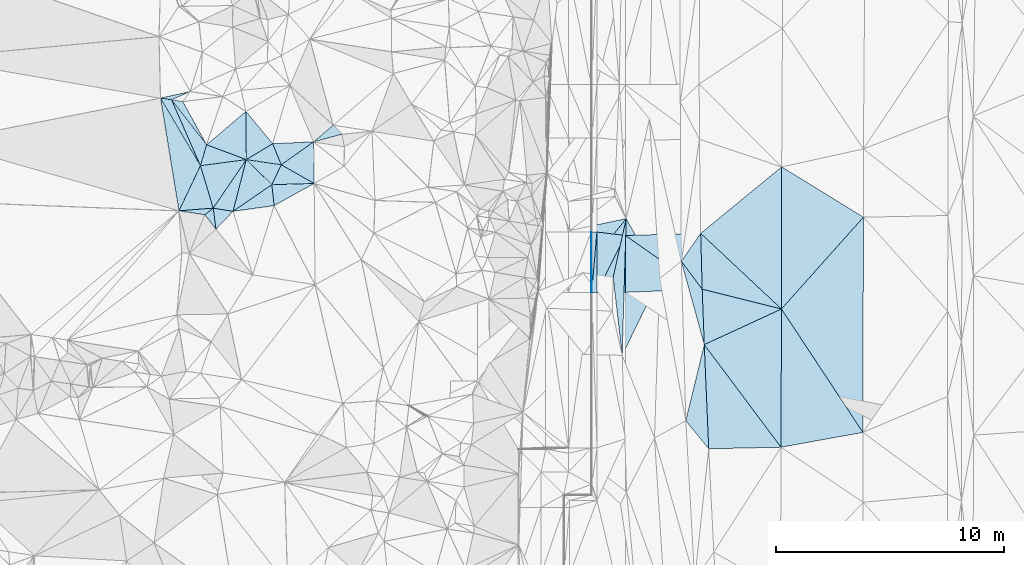
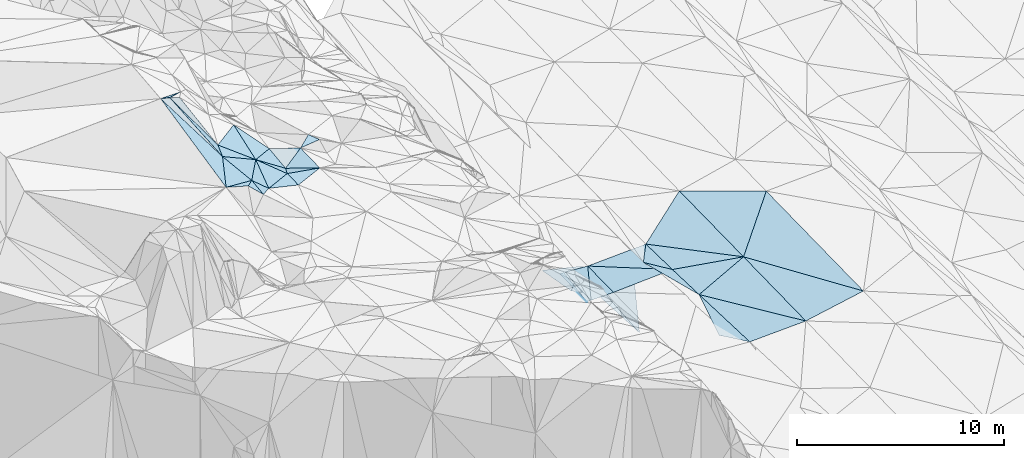
# One storey, part 131 of 275: 45 plates.
"""IFC2X3 building model written with IfcOpenShell, lengths in millimetres."""

from ifc_helpers import new_model, si_unit, frame, origin_with_axes, place, context, subcontext, project, spatial, polyline, outline, extrude, material, type_object, element, save


model = new_model("IFC2X3")

# Units and contexts
model_context = context("Model", 3, precision=1e-05, world=origin_with_axes())
body_context = subcontext(model_context, "Body", "Model", "MODEL_VIEW")
ifc_project = project(units=[si_unit("LENGTHUNIT", "METRE", prefix="MILLI"), si_unit("AREAUNIT", "SQUARE_METRE"), si_unit("VOLUMEUNIT", "CUBIC_METRE"), si_unit("MASSUNIT", "GRAM", prefix="KILO"), si_unit("TIMEUNIT", "SECOND"), si_unit("PLANEANGLEUNIT", "RADIAN"), si_unit("SOLIDANGLEUNIT", "STERADIAN"), si_unit("THERMODYNAMICTEMPERATUREUNIT", "DEGREE_CELSIUS"), si_unit("LUMINOUSINTENSITYUNIT", "LUMEN")], contexts=[model_context])

# Site, building, storey
site_placement = place(None, origin_with_axes())
site = spatial("IfcSite", under=ifc_project, at=site_placement, CompositionType="ELEMENT")
building_placement = place(site_placement, origin_with_axes())
building = spatial("IfcBuilding", under=site, at=building_placement, Name="Undefined", CompositionType="ELEMENT")
storey_placement = place(building_placement, origin_with_axes())
storey = spatial("IfcBuildingStorey", under=building, at=storey_placement, Name="Undefined", CompositionType="ELEMENT", Elevation=0.0)

# Plates
ifc_material = material()
plate_type_1 = type_object("IfcPlateType", PredefinedType="NOTDEFINED")
plate_1_placement = place(storey_placement, frame((-95405.636940983, 112422.816588689, 43228.6962356957), z_axis=(0.0261246873811769, 0.0164532221856586, -0.999523282464668), x_axis=(0.447335473809935, 0.89397628480885, 0.0264078789494309)))
element("IfcPlate", 1, at=plate_1_placement, inside=storey, type_object=plate_type_1, material=ifc_material, Name="00_PR", context=body_context, shape_type="SweptSolid", body=[
    extrude(outline(polyline([(0.0, 0.0), (2792.53784179688, 1.42608769237995e-09), (560.604370117188, 1117.71911621094), (0.0, 0.0)])), frame((-8.85201319254618e-08, 2.18876761149539e-07, -0.5000001331573), z_axis=(0.0, 0.0, 1.0), x_axis=(1.0, 0.0, 0.0)), (0.0, 0.0, 1.0), 1.0),
])
plate_type_2 = type_object("IfcPlateType", PredefinedType="NOTDEFINED")
plate_2_placement = place(storey_placement, frame((-95635.6252966192, 112422.742183701, 43217.1966905969), z_axis=(0.0499273217699331, 0.0166259785425644, -0.998614459828408), x_axis=(-0.998752208045219, -0.000305680073562322, -0.0499392979975866)))
element("IfcPlate", 2, at=plate_2_placement, inside=storey, type_object=plate_type_2, material=ifc_material, Name="00_PR", context=body_context, shape_type="SweptSolid", body=[
    extrude(outline(polyline([(0.0, 0.0), (20.0243110656738, 1.45519152283669e-11), (17.8653774261475, 2647.09228515625), (0.0, 0.0)])), frame((-8.85201319254618e-08, 2.18876761149539e-07, -0.5000001331573), z_axis=(0.0, 0.0, 1.0), x_axis=(1.0, 0.0, 0.0)), (0.0, 0.0, 1.0), 1.0),
])
plate_type_3 = type_object("IfcPlateType", PredefinedType="NOTDEFINED")
plate_3_placement = place(storey_placement, frame((-110810.451345239, 120362.844444543, 54179.5572735576), z_axis=(-0.333149446979087, 0.324142895755912, -0.885405460288393), x_axis=(0.565371093081036, -0.682827947620542, -0.462711055688831)))
element("IfcPlate", 3, at=plate_3_placement, inside=storey, type_object=plate_type_3, material=ifc_material, Name="00", context=body_context, shape_type="SweptSolid", body=[
    extrude(outline(polyline([(0.0, 0.0), (2074.72900390625, 2.35741026699543e-09), (1813.5380859375, 1337.41516113281), (0.0, 0.0)])), frame((-8.85201319254618e-08, 2.18876761149539e-07, -0.5000001331573), z_axis=(0.0, 0.0, 1.0), x_axis=(1.0, 0.0, 0.0)), (0.0, 0.0, 1.0), 1.0),
])
plate_type_4 = type_object("IfcPlateType", PredefinedType="NOTDEFINED")
plate_4_placement = place(storey_placement, frame((-95406.4733777292, 115069.543145118, 43272.7196908099), z_axis=(0.0499247074951265, 0.0166259598819332, -0.998614590840496), x_axis=(0.00032097805931429, -0.999861648908334, -0.0166306949762518)))
element("IfcPlate", 4, at=plate_4_placement, inside=storey, type_object=plate_type_4, material=ifc_material, Name="00_PR", context=body_context, shape_type="SweptSolid", body=[
    extrude(outline(polyline([(0.0, 0.0), (2647.0927734375, 1.41153577715158e-08), (2647.28466796875, 230.287506103516), (0.0, 0.0)])), frame((-8.85201319254618e-08, 2.18876761149539e-07, -0.5000001331573), z_axis=(0.0, 0.0, 1.0), x_axis=(1.0, 0.0, 0.0)), (0.0, 0.0, 1.0), 1.0),
])
plate_5_placement = place(storey_placement, frame((-95406.4733777292, 115069.543145118, 43272.7196908099), z_axis=(0.0499247074951265, 0.0166259598819332, -0.998614590840496), x_axis=(-0.0862354459038181, -0.996055651648607, -0.0208946569399736)))
element("IfcPlate", 5, at=plate_5_placement, inside=storey, type_object=plate_type_4, material=ifc_material, Name="00_PR", context=body_context, shape_type="SweptSolid", body=[
    extrude(outline(polyline([(0.0, 0.0), (2657.2822265625, 1.97906047105789e-09), (20.1477832794189, 229.404937744141), (0.0, 0.0)])), frame((-8.85201319254618e-08, 2.18876761149539e-07, -0.5000001331573), z_axis=(0.0, 0.0, 1.0), x_axis=(1.0, 0.0, 0.0)), (0.0, 0.0, 1.0), 1.0),
])
plate_type_5 = type_object("IfcPlateType", PredefinedType="NOTDEFINED")
plate_6_placement = place(storey_placement, frame((-91504.6928822049, 106787.559781468, 43213.5003480507), z_axis=(0.0316971727330136, 0.02102585878124, -0.999276339409297), x_axis=(0.235613999382781, 0.971445754051375, 0.0279139791216917)))
element("IfcPlate", 6, at=plate_6_placement, inside=storey, type_object=plate_type_5, material=ifc_material, Name="00", context=body_context, shape_type="SweptSolid", body=[
    extrude(outline(polyline([(0.0, 0.0), (3439.13720703125, -3.43425199389458e-09), (-958.349670410156, 1267.560546875), (0.0, 0.0)])), frame((-8.85201319254618e-08, 2.18876761149539e-07, -0.5000001331573), z_axis=(0.0, 0.0, 1.0), x_axis=(1.0, 0.0, 0.0)), (0.0, 0.0, 1.0), 1.0),
])
plate_type_6 = type_object("IfcPlateType", PredefinedType="NOTDEFINED")
plate_7_placement = place(storey_placement, frame((-83731.5859896903, 106274.776728056, 43419.5002922952), z_axis=(0.0301084641782559, 0.0180293382803892, -0.999384021958525), x_axis=(-0.983565161469447, -0.177542801450878, -0.032834841198863)))
element("IfcPlate", 7, at=plate_7_placement, inside=storey, type_object=plate_type_6, material=ifc_material, Name="00", context=body_context, shape_type="SweptSolid", body=[
    extrude(outline(polyline([(0.0, 0.0), (3654.65454101563, 4.97675500810146e-09), (2555.42626953125, 5966.26318359375), (0.0, 0.0)])), frame((-8.85201319254618e-08, 2.18876761149539e-07, -0.5000001331573), z_axis=(0.0, 0.0, 1.0), x_axis=(1.0, 0.0, 0.0)), (0.0, 0.0, 1.0), 1.0),
])
plate_type_7 = type_object("IfcPlateType", PredefinedType="NOTDEFINED")
plate_8_placement = place(storey_placement, frame((-109260.471451862, 118019.108223187, 52489.5316507681), z_axis=(-0.167461434060309, -0.307615350329849, -0.936658670137585), x_axis=(0.870447751281367, -0.492223868524003, 0.00603121417938286)))
element("IfcPlate", 8, at=plate_8_placement, inside=storey, type_object=plate_type_7, material=ifc_material, Name="00", context=body_context, shape_type="SweptSolid", body=[
    extrude(outline(polyline([(0.0, 0.0), (1658.041015625, 1.00844772532582e-08), (71.6508178710938, 1026.77465820313), (0.0, 0.0)])), frame((-8.85201319254618e-08, 2.18876761149539e-07, -0.5000001331573), z_axis=(0.0, 0.0, 1.0), x_axis=(1.0, 0.0, 0.0)), (0.0, 0.0, 1.0), 1.0),
])
plate_type_8 = type_object("IfcPlateType", PredefinedType="NOTDEFINED")
plate_9_placement = place(storey_placement, frame((-90852.3322103507, 115011.612105926, 43389.5002367163), z_axis=(0.0258606812985652, 0.0170135601520622, -0.999520767134794), x_axis=(0.0274207330749661, -0.999491018563695, -0.0163035949452734)))
element("IfcPlate", 9, at=plate_9_placement, inside=storey, type_object=plate_type_8, material=ifc_material, Name="00_PR", context=body_context, shape_type="SweptSolid", body=[
    extrude(outline(polyline([(0.0, 0.0), (2453.44653320313, -7.26140569895506e-09), (3.10413932800293, 3306.53833007813), (0.0, 0.0)])), frame((-8.85201319254618e-08, 2.18876761149539e-07, -0.5000001331573), z_axis=(0.0, 0.0, 1.0), x_axis=(1.0, 0.0, 0.0)), (0.0, 0.0, 1.0), 1.0),
])
plate_type_9 = type_object("IfcPlateType", PredefinedType="NOTDEFINED")
plate_10_placement = place(storey_placement, frame((-94155.6353564772, 112423.45540661, 43261.3782270843), z_axis=(0.0254687798570061, 0.0164532902279957, -0.999540209543002), x_axis=(-0.000320776086039188, 0.999864630622085, 0.0164504569439303)))
element("IfcPlate", 10, at=plate_10_placement, inside=storey, type_object=plate_type_9, material=ifc_material, Name="00_PR", context=body_context, shape_type="SweptSolid", body=[
    extrude(outline(polyline([(0.0, 0.0), (2496.16162109375, 6.53380993753672e-09), (136.308670043945, 3371.7158203125), (0.0, 0.0)])), frame((-8.85201319254618e-08, 2.18876761149539e-07, -0.5000001331573), z_axis=(0.0, 0.0, 1.0), x_axis=(1.0, 0.0, 0.0)), (0.0, 0.0, 1.0), 1.0),
])
plate_type_10 = type_object("IfcPlateType", PredefinedType="NOTDEFINED")
plate_11_placement = place(storey_placement, frame((-94156.43591932, 114919.279210571, 43302.4412324462), z_axis=(0.0257649185416338, 0.0166334341326366, -0.999529638300685), x_axis=(-0.447335473803336, -0.893976284812202, -0.0264078789477062)))
element("IfcPlate", 11, at=plate_11_placement, inside=storey, type_object=plate_type_10, material=ifc_material, Name="00_PR", context=body_context, shape_type="SweptSolid", body=[
    extrude(outline(polyline([(0.0, 0.0), (2792.53784179688, 1.42608769237995e-09), (425.644012451172, 1185.29052734375), (0.0, 0.0)])), frame((-8.85201319254618e-08, 2.18876761149539e-07, -0.5000001331573), z_axis=(0.0, 0.0, 1.0), x_axis=(1.0, 0.0, 0.0)), (0.0, 0.0, 1.0), 1.0),
])
plate_type_11 = type_object("IfcPlateType", PredefinedType="NOTDEFINED")
plate_12_placement = place(storey_placement, frame((-87297.9630248133, 117927.821344053, 43519.5002951213), z_axis=(0.0303062663931262, 0.0175832771455404, -0.999385990787409), x_axis=(0.851678424281376, -0.523801420466456, 0.0166112471210248)))
element("IfcPlate", 12, at=plate_12_placement, inside=storey, type_object=plate_type_11, material=ifc_material, Name="00", context=body_context, shape_type="SweptSolid", body=[
    extrude(outline(polyline([(0.0, 0.0), (4214.01220703125, 2.6695488486439e-08), (3256.89599609375, 5319.36376953125), (0.0, 0.0)])), frame((-8.85201319254618e-08, 2.18876761149539e-07, -0.5000001331573), z_axis=(0.0, 0.0, 1.0), x_axis=(1.0, 0.0, 0.0)), (0.0, 0.0, 1.0), 1.0),
])
plate_type_12 = type_object("IfcPlateType", PredefinedType="NOTDEFINED")
plate_13_placement = place(storey_placement, frame((-112247.445334305, 116119.360208857, 53969.5605613651), z_axis=(-0.469479205979258, 0.0851227212068023, -0.878830698990104), x_axis=(-0.279987594316472, 0.929619335914699, 0.239613933907002)))
element("IfcPlate", 13, at=plate_13_placement, inside=storey, type_object=plate_type_12, material=ifc_material, Name="00", context=body_context, shape_type="SweptSolid", body=[
    extrude(outline(polyline([(0.0, 0.0), (2003.22241210938, -5.07861841470003e-09), (1436.08618164063, 2215.45849609375), (0.0, 0.0)])), frame((-8.85201319254618e-08, 2.18876761149539e-07, -0.5000001331573), z_axis=(0.0, 0.0, 1.0), x_axis=(1.0, 0.0, 0.0)), (0.0, 0.0, 1.0), 1.0),
])
plate_type_13 = type_object("IfcPlateType", PredefinedType="NOTDEFINED")
plate_14_placement = place(storey_placement, frame((-114076.75176983, 120875.741007208, 56609.5072609217), z_axis=(-0.168092678600507, -0.0259665844328717, -0.985429138951045), x_axis=(-0.975777586513747, 0.146365106783971, 0.162589535867238)))
element("IfcPlate", 14, at=plate_14_placement, inside=storey, type_object=plate_type_13, material=ifc_material, Name="00", context=body_context, shape_type="SweptSolid", body=[
    extrude(outline(polyline([(0.0, 0.0), (492.036590576172, -2.88127921521664e-09), (-774.332641601563, 482.606384277344), (0.0, 0.0)])), frame((-8.85201319254618e-08, 2.18876761149539e-07, -0.5000001331573), z_axis=(0.0, 0.0, 1.0), x_axis=(1.0, 0.0, 0.0)), (0.0, 0.0, 1.0), 1.0),
])
plate_type_14 = type_object("IfcPlateType", PredefinedType="NOTDEFINED")
plate_15_placement = place(storey_placement, frame((-90852.3345467828, 115011.612065453, 43389.5001743786), z_axis=(0.0214611120003879, 0.01689459160839, -0.999626927131364), x_axis=(0.729896136613249, -0.683545663692142, 0.00411769410269381)))
element("IfcPlate", 15, at=plate_15_placement, inside=storey, type_object=plate_type_14, material=ifc_material, Name="00", context=body_context, shape_type="SweptSolid", body=[
    extrude(outline(polyline([(0.0, 0.0), (4857.08740234375, -8.96761775948107e-09), (1725.12841796875, 1744.51477050781), (0.0, 0.0)])), frame((-8.85201319254618e-08, 2.18876761149539e-07, -0.5000001331573), z_axis=(0.0, 0.0, 1.0), x_axis=(1.0, 0.0, 0.0)), (0.0, 0.0, 1.0), 1.0),
])
plate_type_15 = type_object("IfcPlateType", PredefinedType="NOTDEFINED")
plate_16_placement = place(storey_placement, frame((-112247.280751228, 116119.437887726, 53969.5197449897), z_axis=(-0.140308210808495, 0.240475135443113, -0.960460990989918), x_axis=(-0.778823341562856, -0.625774264014249, -0.04290423212565)))
element("IfcPlate", 16, at=plate_16_placement, inside=storey, type_object=plate_type_15, material=ifc_material, Name="00", context=body_context, shape_type="SweptSolid", body=[
    extrude(outline(polyline([(0.0, 0.0), (466.154479980469, 8.14907252788544e-10), (1233.92565917969, 883.134948730469), (0.0, 0.0)])), frame((-8.85201319254618e-08, 2.18876761149539e-07, -0.5000001331573), z_axis=(0.0, 0.0, 1.0), x_axis=(1.0, 0.0, 0.0)), (0.0, 0.0, 1.0), 1.0),
])
plate_type_16 = type_object("IfcPlateType", PredefinedType="NOTDEFINED")
plate_17_placement = place(storey_placement, frame((-112808.111734824, 117981.8439339, 54449.5947935813), z_axis=(-0.0474280549861626, 0.584002768198954, -0.810364946389087), x_axis=(-0.425702089397199, 0.722094766052242, 0.545304391989297)))
element("IfcPlate", 17, at=plate_17_placement, inside=storey, type_object=plate_type_16, material=ifc_material, Name="00", context=body_context, shape_type="SweptSolid", body=[
    extrude(outline(polyline([(0.0, 0.0), (4107.79736328125, 2.93475750368088e-08), (3807.78271484375, 389.988616943359), (0.0, 0.0)])), frame((-8.85201319254618e-08, 2.18876761149539e-07, -0.5000001331573), z_axis=(0.0, 0.0, 1.0), x_axis=(1.0, 0.0, 0.0)), (0.0, 0.0, 1.0), 1.0),
])
plate_type_17 = type_object("IfcPlateType", PredefinedType="NOTDEFINED")
plate_18_placement = place(storey_placement, frame((-114077.007323834, 120875.865953899, 56609.6505046709), z_axis=(-0.679220038633358, 0.223920091982864, -0.698942008699782), x_axis=(0.468447307258022, -0.600844201840946, -0.647721672816978)))
element("IfcPlate", 18, at=plate_18_placement, inside=storey, type_object=plate_type_17, material=ifc_material, Name="00", context=body_context, shape_type="SweptSolid", body=[
    extrude(outline(polyline([(0.0, 0.0), (3288.44946289063, -1.75787135958672e-08), (3732.30615234375, 849.229858398438), (0.0, 0.0)])), frame((-8.85201319254618e-08, 2.18876761149539e-07, -0.5000001331573), z_axis=(0.0, 0.0, 1.0), x_axis=(1.0, 0.0, 0.0)), (0.0, 0.0, 1.0), 1.0),
])
plate_type_18 = type_object("IfcPlateType", PredefinedType="NOTDEFINED")
plate_19_placement = place(storey_placement, frame((-91700.2194737147, 113786.127213955, 43348.5002071159), z_axis=(0.0243564551170014, 0.0173557682872475, -0.999552670148649), x_axis=(0.597960238344187, -0.80152549955492, 0.000653393142643514)))
element("IfcPlate", 19, at=plate_19_placement, inside=storey, type_object=plate_type_18, material=ifc_material, Name="00", context=body_context, shape_type="SweptSolid", body=[
    extrude(outline(polyline([(0.0, 0.0), (1530.47253417969, -8.04175215307623e-09), (3533.10888671875, 1381.53796386719), (0.0, 0.0)])), frame((-8.85201319254618e-08, 2.18876761149539e-07, -0.5000001331573), z_axis=(0.0, 0.0, 1.0), x_axis=(1.0, 0.0, 0.0)), (0.0, 0.0, 1.0), 1.0),
])
plate_type_19 = type_object("IfcPlateType", PredefinedType="NOTDEFINED")
plate_20_placement = place(storey_placement, frame((-90785.0580638495, 112559.414298806, 43349.5002018653), z_axis=(0.0238239995066291, 0.016958525722787, -0.999572321271862), x_axis=(-0.597960238451946, 0.80152549947459, -0.000653393067869697)))
element("IfcPlate", 20, at=plate_20_placement, inside=storey, type_object=plate_type_19, material=ifc_material, Name="00", context=body_context, shape_type="SweptSolid", body=[
    extrude(outline(polyline([(0.0, 0.0), (1530.47253417969, -8.04175215307623e-09), (2005.70092773438, 1412.99816894531), (0.0, 0.0)])), frame((-8.85201319254618e-08, 2.18876761149539e-07, -0.5000001331573), z_axis=(0.0, 0.0, 1.0), x_axis=(1.0, 0.0, 0.0)), (0.0, 0.0, 1.0), 1.0),
])
plate_type_20 = type_object("IfcPlateType", PredefinedType="NOTDEFINED")
plate_21_placement = place(storey_placement, frame((-110794.292101968, 118248.76264126, 53399.5323429697), z_axis=(-0.327778066512449, 0.133555370756582, -0.935267075254674), x_axis=(0.673370976289201, -0.661351238839489, -0.330433150844163)))
element("IfcPlate", 21, at=plate_21_placement, inside=storey, type_object=plate_type_20, material=ifc_material, Name="00", context=body_context, shape_type="SweptSolid", body=[
    extrude(outline(polyline([(0.0, 0.0), (1664.48193359375, 2.47382558882236e-10), (1148.34533691406, 2045.43469238281), (0.0, 0.0)])), frame((-8.85201319254618e-08, 2.18876761149539e-07, -0.5000001331573), z_axis=(0.0, 0.0, 1.0), x_axis=(1.0, 0.0, 0.0)), (0.0, 0.0, 1.0), 1.0),
])
plate_type_21 = type_object("IfcPlateType", PredefinedType="NOTDEFINED")
plate_22_placement = place(storey_placement, frame((-112536.439062668, 118899.992358749, 54479.5676101874), z_axis=(-0.473170055004703, 0.16833369986897, -0.864739188735696), x_axis=(0.810021777325781, -0.302797759622453, -0.502173512867422)))
element("IfcPlate", 22, at=plate_22_placement, inside=storey, type_object=plate_type_21, material=ifc_material, Name="00", context=body_context, shape_type="SweptSolid", body=[
    extrude(outline(polyline([(0.0, 0.0), (2150.65112304688, -2.18278728425503e-09), (72.9081573486328, 955.449829101563), (0.0, 0.0)])), frame((-8.85201319254618e-08, 2.18876761149539e-07, -0.5000001331573), z_axis=(0.0, 0.0, 1.0), x_axis=(1.0, 0.0, 0.0)), (0.0, 0.0, 1.0), 1.0),
])
plate_type_22 = type_object("IfcPlateType", PredefinedType="NOTDEFINED")
plate_23_placement = place(storey_placement, frame((-112125.234215423, 115200.334073739, 53659.5306548207), z_axis=(-0.183119795640212, 0.292261494062498, -0.938642828520542), x_axis=(-0.574478656324215, 0.742992933903219, 0.343417782879414)))
element("IfcPlate", 23, at=plate_23_placement, inside=storey, type_object=plate_type_22, material=ifc_material, Name="00", context=body_context, shape_type="SweptSolid", body=[
    extrude(outline(polyline([(0.0, 0.0), (844.452514648438, 7.05767888575792e-10), (859.491821289063, 465.911804199219), (0.0, 0.0)])), frame((-8.85201319254618e-08, 2.18876761149539e-07, -0.5000001331573), z_axis=(0.0, 0.0, 1.0), x_axis=(1.0, 0.0, 0.0)), (0.0, 0.0, 1.0), 1.0),
])
plate_type_23 = type_object("IfcPlateType", PredefinedType="NOTDEFINED")
plate_24_placement = place(storey_placement, frame((-114557.019264945, 120947.941572312, 56689.5919586894), z_axis=(-0.466566159231337, 0.341184935880078, -0.816032388198303), x_axis=(0.425702089407616, -0.722094766050043, -0.545304391984078)))
element("IfcPlate", 24, at=plate_24_placement, inside=storey, type_object=plate_type_23, material=ifc_material, Name="00", context=body_context, shape_type="SweptSolid", body=[
    extrude(outline(polyline([(0.0, 0.0), (4107.79736328125, 2.93475750368088e-08), (5294.85693359375, 1864.2666015625), (0.0, 0.0)])), frame((-8.85201319254618e-08, 2.18876761149539e-07, -0.5000001331573), z_axis=(0.0, 0.0, 1.0), x_axis=(1.0, 0.0, 0.0)), (0.0, 0.0, 1.0), 1.0),
])
plate_type_24 = type_object("IfcPlateType", PredefinedType="NOTDEFINED")
plate_25_placement = place(storey_placement, frame((-90694.387517746, 110128.494769357, 43309.5002485413), z_axis=(0.0247485720366945, 0.0207332777010844, -0.999478683803669), x_axis=(0.599005774649068, -0.800742729715123, -0.00177841093243234)))
element("IfcPlate", 25, at=plate_25_placement, inside=storey, type_object=plate_type_24, material=ifc_material, Name="00", context=body_context, shape_type="SweptSolid", body=[
    extrude(outline(polyline([(0.0, 0.0), (5622.99755859375, 5.17811713507399e-08), (3777.61157226563, 2583.45727539063), (0.0, 0.0)])), frame((-8.85201319254618e-08, 2.18876761149539e-07, -0.5000001331573), z_axis=(0.0, 0.0, 1.0), x_axis=(1.0, 0.0, 0.0)), (0.0, 0.0, 1.0), 1.0),
])
plate_type_25 = type_object("IfcPlateType", PredefinedType="NOTDEFINED")
plate_26_placement = place(storey_placement, frame((-94120.5754329016, 115659.537541605, 42829.5350744156), z_axis=(-0.365689924590976, 0.0416241977210029, -0.929805520104462), x_axis=(-0.217102617388878, -0.975256537191867, 0.0417269719417328)))
element("IfcPlate", 26, at=plate_26_placement, inside=storey, type_object=plate_type_25, material=ifc_material, Name="00", context=body_context, shape_type="SweptSolid", body=[
    extrude(outline(polyline([(0.0, 0.0), (2636.1845703125, -1.60507624968886e-08), (2749.2607421875, 1436.45874023438), (0.0, 0.0)])), frame((-8.85201319254618e-08, 2.18876761149539e-07, -0.5000001331573), z_axis=(0.0, 0.0, 1.0), x_axis=(1.0, 0.0, 0.0)), (0.0, 0.0, 1.0), 1.0),
])
plate_type_26 = type_object("IfcPlateType", PredefinedType="NOTDEFINED")
plate_27_placement = place(storey_placement, frame((-109673.473911803, 117147.948177686, 52849.5298513023), z_axis=(-0.3190273921008, 0.118966910757661, -0.940249114455388), x_axis=(0.10660010432155, -0.981290449113987, -0.160329261946483)))
element("IfcPlate", 27, at=plate_27_placement, inside=storey, type_object=plate_type_26, material=ifc_material, Name="00", context=body_context, shape_type="SweptSolid", body=[
    extrude(outline(polyline([(0.0, 0.0), (935.57470703125, -3.73984221369028e-09), (896.026794433594, 1909.79992675781), (0.0, 0.0)])), frame((-8.85201319254618e-08, 2.18876761149539e-07, -0.5000001331573), z_axis=(0.0, 0.0, 1.0), x_axis=(1.0, 0.0, 0.0)), (0.0, 0.0, 1.0), 1.0),
])
plate_type_27 = type_object("IfcPlateType", PredefinedType="NOTDEFINED")
plate_28_placement = place(storey_placement, frame((-112536.215856425, 118900.269738829, 54479.6548712811), z_axis=(-0.0268695331726765, 0.723110482317303, -0.690209575817317), x_axis=(-0.468447307269566, 0.600844201829089, 0.647721672819628)))
element("IfcPlate", 28, at=plate_28_placement, inside=storey, type_object=plate_type_27, material=ifc_material, Name="00", context=body_context, shape_type="SweptSolid", body=[
    extrude(outline(polyline([(0.0, 0.0), (3288.44946289063, -1.75787135958672e-08), (2946.25170898438, 377.095092773438), (0.0, 0.0)])), frame((-8.85201319254618e-08, 2.18876761149539e-07, -0.5000001331573), z_axis=(0.0, 0.0, 1.0), x_axis=(1.0, 0.0, 0.0)), (0.0, 0.0, 1.0), 1.0),
])
plate_type_28 = type_object("IfcPlateType", PredefinedType="NOTDEFINED")
plate_29_placement = place(storey_placement, frame((-109573.675791635, 116229.887445831, 52699.5137505906), z_axis=(-0.187488930086471, 0.138517599537016, -0.972450911724357), x_axis=(-0.10660010431827, 0.98129044911275, 0.160329261956239)))
element("IfcPlate", 29, at=plate_29_placement, inside=storey, type_object=plate_type_28, material=ifc_material, Name="00", context=body_context, shape_type="SweptSolid", body=[
    extrude(outline(polyline([(0.0, 0.0), (935.57470703125, -3.73984221369028e-09), (735.804443359375, 1879.09338378906), (0.0, 0.0)])), frame((-8.85201319254618e-08, 2.18876761149539e-07, -0.5000001331573), z_axis=(0.0, 0.0, 1.0), x_axis=(1.0, 0.0, 0.0)), (0.0, 0.0, 1.0), 1.0),
])
plate_type_29 = type_object("IfcPlateType", PredefinedType="NOTDEFINED")
plate_30_placement = place(storey_placement, frame((-106979.633588099, 119760.305384308, 52629.5278212714), z_axis=(-0.179387568007321, 0.275855302357618, -0.944311364225596), x_axis=(0.667943781868984, -0.670571696413419, -0.3227765546501)))
element("IfcPlate", 30, at=plate_30_placement, inside=storey, type_object=plate_type_29, material=ifc_material, Name="00", context=body_context, shape_type="SweptSolid", body=[
    extrude(outline(polyline([(0.0, 0.0), (588.642517089844, -2.47564457822591e-09), (-68.1228408813477, 1125.45959472656), (0.0, 0.0)])), frame((-8.85201319254618e-08, 2.18876761149539e-07, -0.5000001331573), z_axis=(0.0, 0.0, 1.0), x_axis=(1.0, 0.0, 0.0)), (0.0, 0.0, 1.0), 1.0),
])
plate_type_30 = type_object("IfcPlateType", PredefinedType="NOTDEFINED")
plate_31_placement = place(storey_placement, frame((-111376.611438892, 115979.616903231, 53279.6080134496), z_axis=(-0.590137702703882, 0.192864060661721, -0.783926620260122), x_axis=(-0.777677128218946, 0.124833835811116, 0.616145110896627)))
element("IfcPlate", 31, at=plate_31_placement, inside=storey, type_object=plate_type_30, material=ifc_material, Name="00", context=body_context, shape_type="SweptSolid", body=[
    extrude(outline(polyline([(0.0, 0.0), (1119.86608886719, -5.5297277867794e-09), (-95.5471420288086, 2343.79418945313), (0.0, 0.0)])), frame((-8.85201319254618e-08, 2.18876761149539e-07, -0.5000001331573), z_axis=(0.0, 0.0, 1.0), x_axis=(1.0, 0.0, 0.0)), (0.0, 0.0, 1.0), 1.0),
])
plate_type_31 = type_object("IfcPlateType", PredefinedType="NOTDEFINED")
plate_32_placement = place(storey_placement, frame((-113748.193934707, 116002.557219542, 54159.5158346942), z_axis=(-0.138753342677596, 0.207789123790375, -0.968282598175874), x_axis=(0.425334130671733, 0.895473897031596, 0.131215003032305)))
element("IfcPlate", 32, at=plate_32_placement, inside=storey, type_object=plate_type_31, material=ifc_material, Name="00", context=body_context, shape_type="SweptSolid", body=[
    extrude(outline(polyline([(0.0, 0.0), (2210.11303710938, 7.30506144464016e-09), (718.108032226563, 1336.72021484375), (0.0, 0.0)])), frame((-8.85201319254618e-08, 2.18876761149539e-07, -0.5000001331573), z_axis=(0.0, 0.0, 1.0), x_axis=(1.0, 0.0, 0.0)), (0.0, 0.0, 1.0), 1.0),
])
plate_type_32 = type_object("IfcPlateType", PredefinedType="NOTDEFINED")
plate_33_placement = place(storey_placement, frame((-112247.506419418, 116119.410649503, 53969.6077536076), z_axis=(-0.591650654441124, 0.185998145387024, -0.784445149779115), x_axis=(0.77767712822132, -0.124833835817405, -0.616145110892356)))
element("IfcPlate", 33, at=plate_33_placement, inside=storey, type_object=plate_type_32, material=ifc_material, Name="00", context=body_context, shape_type="SweptSolid", body=[
    extrude(outline(polyline([(0.0, 0.0), (1119.86608886719, -5.5297277867794e-09), (400.672912597656, 891.774169921875), (0.0, 0.0)])), frame((-8.85201319254618e-08, 2.18876761149539e-07, -0.5000001331573), z_axis=(0.0, 0.0, 1.0), x_axis=(1.0, 0.0, 0.0)), (0.0, 0.0, 1.0), 1.0),
])
plate_type_33 = type_object("IfcPlateType", PredefinedType="NOTDEFINED")
plate_34_placement = place(storey_placement, frame((-107817.133655351, 117203.156702707, 52499.5007160068), z_axis=(0.0318388544012577, 0.0440689012602255, -0.998521015949155), x_axis=(-0.870447751147329, 0.492223868760635, -0.00603121421197014)))
element("IfcPlate", 34, at=plate_34_placement, inside=storey, type_object=plate_type_33, material=ifc_material, Name="00", context=body_context, shape_type="SweptSolid", body=[
    extrude(outline(polyline([(0.0, 0.0), (1658.041015625, 1.00844772532582e-08), (917.226989746094, 1583.00183105469), (0.0, 0.0)])), frame((-8.85201319254618e-08, 2.18876761149539e-07, -0.5000001331573), z_axis=(0.0, 0.0, 1.0), x_axis=(1.0, 0.0, 0.0)), (0.0, 0.0, 1.0), 1.0),
])
plate_type_34 = type_object("IfcPlateType", PredefinedType="NOTDEFINED")
plate_35_placement = place(storey_placement, frame((-109673.573900178, 117147.836417893, 52849.5757953401), z_axis=(-0.51899068081089, -0.104553355556667, -0.848361520269095), x_axis=(-0.673370976277538, 0.661351238854098, 0.330433150838691)))
element("IfcPlate", 35, at=plate_35_placement, inside=storey, type_object=plate_type_34, material=ifc_material, Name="00", context=body_context, shape_type="SweptSolid", body=[
    extrude(outline(polyline([(0.0, 0.0), (1664.48193359375, 2.47382558882236e-10), (179.275009155273, 1013.53857421875), (0.0, 0.0)])), frame((-8.85201319254618e-08, 2.18876761149539e-07, -0.5000001331573), z_axis=(0.0, 0.0, 1.0), x_axis=(1.0, 0.0, 0.0)), (0.0, 0.0, 1.0), 1.0),
])
plate_36_placement = place(storey_placement, frame((-109637.493478237, 118946.229848094, 53219.6040500651), z_axis=(-0.400905517514622, 0.46070064910051, -0.791852055591638), x_axis=(0.304332246299246, -0.748294158870283, -0.589438491840388)))
element("IfcPlate", 36, at=plate_36_placement, inside=storey, type_object=plate_type_34, material=ifc_material, Name="00", context=body_context, shape_type="SweptSolid", body=[
    extrude(outline(polyline([(0.0, 0.0), (1238.466796875, -9.5242285169661e-09), (63.6270599365234, 1361.19494628906), (0.0, 0.0)])), frame((-8.85201319254618e-08, 2.18876761149539e-07, -0.5000001331573), z_axis=(0.0, 0.0, 1.0), x_axis=(1.0, 0.0, 0.0)), (0.0, 0.0, 1.0), 1.0),
])
plate_type_35 = type_object("IfcPlateType", PredefinedType="NOTDEFINED")
plate_37_placement = place(storey_placement, frame((-110794.334926583, 118248.852065101, 53399.5723453138), z_axis=(-0.413437452773197, 0.312406854500872, -0.855261030273964), x_axis=(-0.810021777257706, 0.302797759829426, 0.50217351285243)))
element("IfcPlate", 37, at=plate_37_placement, inside=storey, type_object=plate_type_35, material=ifc_material, Name="00", context=body_context, shape_type="SweptSolid", body=[
    extrude(outline(polyline([(0.0, 0.0), (2150.65112304688, -2.18278728425503e-09), (1044.89294433594, 1996.44653320313), (0.0, 0.0)])), frame((-8.85201319254618e-08, 2.18876761149539e-07, -0.5000001331573), z_axis=(0.0, 0.0, 1.0), x_axis=(1.0, 0.0, 0.0)), (0.0, 0.0, 1.0), 1.0),
])
plate_type_36 = type_object("IfcPlateType", PredefinedType="NOTDEFINED")
plate_38_placement = place(storey_placement, frame((-109260.542600199, 118019.515704959, 52489.5979332433), z_axis=(-0.309909557167287, 0.507346340612513, -0.804086908887011), x_axis=(-0.304332246297121, 0.748294158868724, 0.589438491843464)))
element("IfcPlate", 38, at=plate_38_placement, inside=storey, type_object=plate_type_36, material=ifc_material, Name="00", context=body_context, shape_type="SweptSolid", body=[
    extrude(outline(polyline([(0.0, 0.0), (1238.466796875, -9.5242285169661e-09), (377.079132080078, 1706.60815429688), (0.0, 0.0)])), frame((-8.85201319254618e-08, 2.18876761149539e-07, -0.5000001331573), z_axis=(0.0, 0.0, 1.0), x_axis=(1.0, 0.0, 0.0)), (0.0, 0.0, 1.0), 1.0),
])
plate_type_37 = type_object("IfcPlateType", PredefinedType="NOTDEFINED")
plate_39_placement = place(storey_placement, frame((-90852.3342204879, 115011.612415662, 43389.5001880117), z_axis=(0.0221207621483594, 0.0175991316075092, -0.999600391380794), x_axis=(0.772785285257558, 0.634037874268127, 0.0282644101822502)))
element("IfcPlate", 39, at=plate_39_placement, inside=storey, type_object=plate_type_37, material=ifc_material, Name="00", context=body_context, shape_type="SweptSolid", body=[
    extrude(outline(polyline([(0.0, 0.0), (4599.423828125, -4.07453626394272e-09), (635.188232421875, 4815.375), (0.0, 0.0)])), frame((-8.85201319254618e-08, 2.18876761149539e-07, -0.5000001331573), z_axis=(0.0, 0.0, 1.0), x_axis=(1.0, 0.0, 0.0)), (0.0, 0.0, 1.0), 1.0),
])
plate_type_38 = type_object("IfcPlateType", PredefinedType="NOTDEFINED")
plate_40_placement = place(storey_placement, frame((-94120.5883019913, 115659.540639998, 42829.5404948648), z_axis=(-0.391430241021267, 0.0478181082988184, -0.918964523217711), x_axis=(-0.0294057613476194, -0.998788905857676, -0.0394464540255819)))
element("IfcPlate", 40, at=plate_40_placement, inside=storey, type_object=plate_type_38, material=ifc_material, Name="00", context=body_context, shape_type="SweptSolid", body=[
    extrude(outline(polyline([(0.0, 0.0), (6008.14453125, 1.60944182425737e-08), (2580.3330078125, 539.768920898438), (0.0, 0.0)])), frame((-8.85201319254618e-08, 2.18876761149539e-07, -0.5000001331573), z_axis=(0.0, 0.0, 1.0), x_axis=(1.0, 0.0, 0.0)), (0.0, 0.0, 1.0), 1.0),
])
plate_type_39 = type_object("IfcPlateType", PredefinedType="NOTDEFINED")
plate_41_placement = place(storey_placement, frame((-96017.5297727077, 113290.188650756, 43469.5343395903), z_axis=(-0.362278985112308, 0.03849655735857, -0.931274369891889), x_axis=(-0.294075425476065, 0.943392284311949, 0.153397007897007)))
element("IfcPlate", 41, at=plate_41_placement, inside=storey, type_object=plate_type_39, material=ifc_material, Name="00", context=body_context, shape_type="SweptSolid", body=[
    extrude(outline(polyline([(0.0, 0.0), (1955.70959472656, 1.11685949377716e-08), (1579.20178222656, 2669.82592773438), (0.0, 0.0)])), frame((-8.85201319254618e-08, 2.18876761149539e-07, -0.5000001331573), z_axis=(0.0, 0.0, 1.0), x_axis=(1.0, 0.0, 0.0)), (0.0, 0.0, 1.0), 1.0),
])
plate_type_40 = type_object("IfcPlateType", PredefinedType="NOTDEFINED")
plate_42_placement = place(storey_placement, frame((-90785.0592007371, 112559.414446902, 43349.5001784368), z_axis=(0.0215502055044939, 0.0172521890986114, -0.99961890268943), x_axis=(0.970113518834605, -0.242073665251291, 0.0167362231745051)))
element("IfcPlate", 42, at=plate_42_placement, inside=storey, type_object=plate_type_40, material=ifc_material, Name="00", context=body_context, shape_type="SweptSolid", body=[
    extrude(outline(polyline([(0.0, 0.0), (3585.03833007813, 8.61473381519318e-09), (675.752868652344, 2337.21166992188), (0.0, 0.0)])), frame((-8.85201319254618e-08, 2.18876761149539e-07, -0.5000001331573), z_axis=(0.0, 0.0, 1.0), x_axis=(1.0, 0.0, 0.0)), (0.0, 0.0, 1.0), 1.0),
])
plate_type_41 = type_object("IfcPlateType", PredefinedType="NOTDEFINED")
plate_43_placement = place(storey_placement, frame((-90694.3893038083, 110128.4934337, 43309.5001814389), z_axis=(0.0211765587122082, 0.0180614854376342, -0.999612593010359), x_axis=(0.907659458463652, 0.418851109500763, 0.0267965582015772)))
element("IfcPlate", 43, at=plate_43_placement, inside=storey, type_object=plate_type_41, material=ifc_material, Name="00", context=body_context, shape_type="SweptSolid", body=[
    extrude(outline(polyline([(0.0, 0.0), (3731.82250976563, -6.25732354819775e-09), (1171.00952148438, 5499.71240234375), (0.0, 0.0)])), frame((-8.85201319254618e-08, 2.18876761149539e-07, -0.5000001331573), z_axis=(0.0, 0.0, 1.0), x_axis=(1.0, 0.0, 0.0)), (0.0, 0.0, 1.0), 1.0),
])
plate_type_42 = type_object("IfcPlateType", PredefinedType="NOTDEFINED")
plate_44_placement = place(storey_placement, frame((-87307.1608306492, 111691.571405008, 43409.5002927729), z_axis=(0.0299351695474877, 0.0179149340021617, -0.999391285115025), x_axis=(0.665739906413915, 0.745440294302318, 0.033303823180904)))
element("IfcPlate", 44, at=plate_44_placement, inside=storey, type_object=plate_type_42, material=ifc_material, Name="00", context=body_context, shape_type="SweptSolid", body=[
    extrude(outline(polyline([(0.0, 0.0), (5404.78515625, -3.64670995622873e-08), (-1657.16125488281, 6275.3740234375), (0.0, 0.0)])), frame((-8.85201319254618e-08, 2.18876761149539e-07, -0.5000001331573), z_axis=(0.0, 0.0, 1.0), x_axis=(1.0, 0.0, 0.0)), (0.0, 0.0, 1.0), 1.0),
])
plate_type_43 = type_object("IfcPlateType", PredefinedType="NOTDEFINED")
plate_45_placement = place(storey_placement, frame((-94296.9207871274, 109658.663098749, 42592.5219757762), z_axis=(0.291823963041582, 0.0291659022390948, -0.95602726150528), x_axis=(0.0294057614691109, 0.998788905853455, 0.0394464540419148)))
element("IfcPlate", 45, at=plate_45_placement, inside=storey, type_object=plate_type_43, material=ifc_material, Name="00", context=body_context, shape_type="SweptSolid", body=[
    extrude(outline(polyline([(0.0, 0.0), (6008.14453125, 1.60944182425737e-08), (3440.24536132813, 1614.84411621094), (0.0, 0.0)])), frame((-8.85201319254618e-08, 2.18876761149539e-07, -0.5000001331573), z_axis=(0.0, 0.0, 1.0), x_axis=(1.0, 0.0, 0.0)), (0.0, 0.0, 1.0), 1.0),
])

save(model, "model.ifc")
